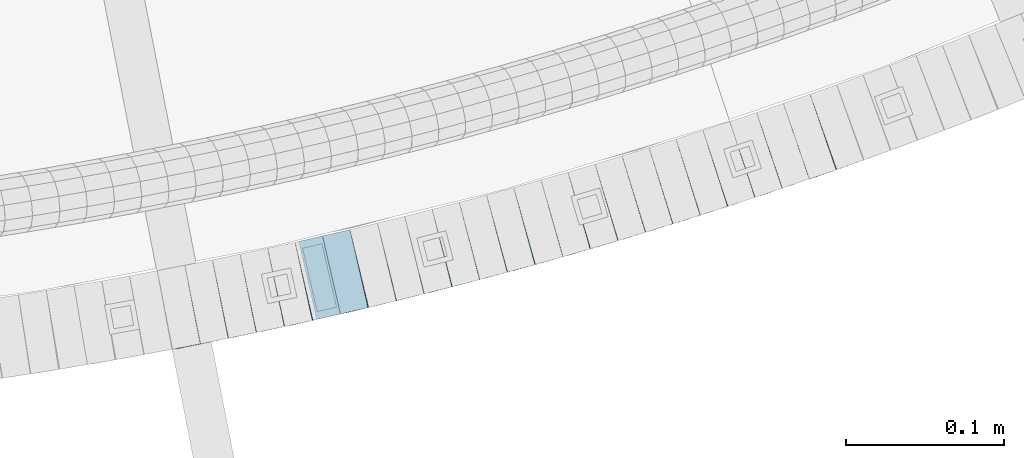
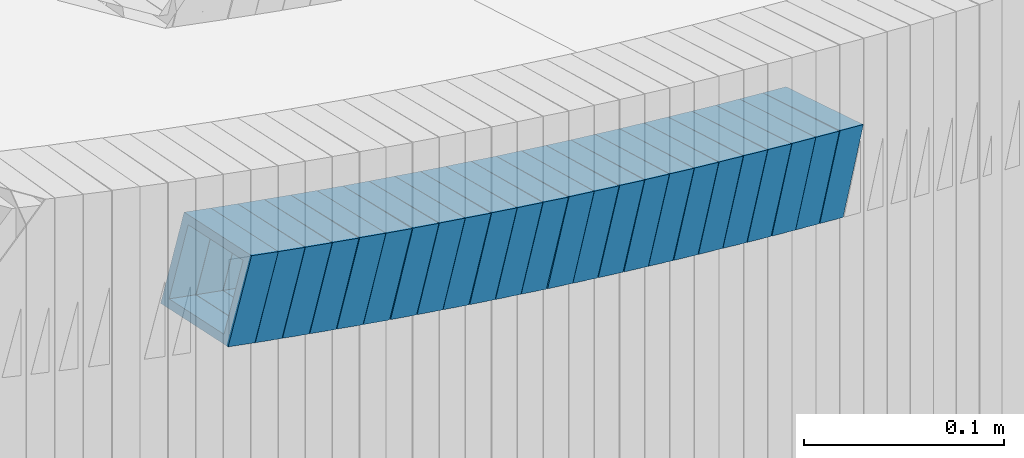
# One storey, part 682 of 975: 24 beams.
"""IFC2X3 building model written with IfcOpenShell, lengths in millimetres."""

from ifc_helpers import new_model, si_unit, frame, origin_with_axes, place, context, subcontext, project, spatial, faceted_brep, material, type_object, element, save


model = new_model("IFC2X3")

# Units and contexts
model_context = context("Model", 3, precision=1e-05, world=origin_with_axes())
body_context = subcontext(model_context, "Body", "Model", "MODEL_VIEW")
ifc_project = project(units=[si_unit("LENGTHUNIT", "METRE", prefix="MILLI"), si_unit("AREAUNIT", "SQUARE_METRE"), si_unit("VOLUMEUNIT", "CUBIC_METRE"), si_unit("MASSUNIT", "GRAM", prefix="KILO"), si_unit("TIMEUNIT", "SECOND"), si_unit("PLANEANGLEUNIT", "RADIAN"), si_unit("SOLIDANGLEUNIT", "STERADIAN"), si_unit("THERMODYNAMICTEMPERATUREUNIT", "DEGREE_CELSIUS"), si_unit("LUMINOUSINTENSITYUNIT", "LUMEN")], contexts=[model_context])

# Site, building, storey
site_placement = place(None, origin_with_axes())
site = spatial("IfcSite", under=ifc_project, at=site_placement, CompositionType="ELEMENT")
building_placement = place(site_placement, origin_with_axes())
building = spatial("IfcBuilding", under=site, at=building_placement, Name="Undefined", CompositionType="ELEMENT")
storey_placement = place(building_placement, origin_with_axes())
storey = spatial("IfcBuildingStorey", under=building, at=storey_placement, Name="Undefined", CompositionType="ELEMENT", Elevation=0.0)

# Beams
ifc_material = material()
beam_type = type_object("IfcBeamType", Name="HSS2X2X.188_TUBES", PredefinedType="NOTDEFINED")
beam_1_placement = place(storey_placement, frame((35282.5013418512, 585.514626684932, 3113.14111426642), z_axis=(-0.201494991724154, 0.979489544768132, -7.25458448869176e-11), x_axis=(0.931628976123351, 0.191649389025373, -0.308768461040888)))
element("IfcBeam", 1, at=beam_1_placement, inside=storey, type_object=beam_type, material=ifc_material, Name="WALL", ObjectType="HSS2X2X.188_TUBES", context=body_context, shape_type="Brep", body=[
    faceted_brep([(0.0, 20.6374999999753, -20.6375000000298), (0.0, -20.6375000000153, -20.6375000000153), (18.7771137292038, -20.637500000008, -20.6374999999862), (18.777113729182, 20.6375000000062, -20.6375000000189), (0.0, -20.6374999999825, 20.6375000000335), (18.7771137291729, -20.6374999999916, 20.6374999999753), (0.0, 20.6375000000116, 20.6375000000189), (18.7771137291529, 20.6375000000207, 20.6374999999389), (0.0, 25.3999999999724, -25.4000000000342), (0.0, 25.400000000016, 25.4000000000196), (18.7771137291475, 25.4000000000251, 25.3999999999287), (18.7771137291857, 25.4000000000051, -25.4000000000196), (0.0, -25.399999999976, 25.4000000000378), (18.7771137291711, -25.3999999999905, 25.3999999999724), (0.0, -25.400000000016, -25.4000000000196), (18.7771137292129, -25.4000000000124, -25.3999999999724)], [[[0, 1, 2, 3]], [[1, 4, 5, 2]], [[4, 6, 7, 5]], [[6, 0, 3, 7]], [[8, 9, 10, 11]], [[9, 12, 13, 10]], [[12, 14, 15, 13]], [[14, 8, 11, 15]], [[13, 15, 11, 10], [5, 7, 3, 2]], [[14, 12, 9, 8], [6, 4, 1, 0]]]),
])
beam_2_placement = place(storey_placement, frame((35300.1214551458, 589.139335705527, 3107.30164874972), z_axis=(-0.201494991724154, 0.979489544768132, -7.25458448869176e-11), x_axis=(0.933150868224818, 0.191962464046246, -0.303940569073235)))
element("IfcBeam", 2, at=beam_2_placement, inside=storey, type_object=beam_type, material=ifc_material, Name="WALL", ObjectType="HSS2X2X.188_TUBES", context=body_context, shape_type="Brep", body=[
    faceted_brep([(0.0, 20.6374999999753, -20.6375000000298), (0.0, -20.6375000000153, -20.6375000000153), (18.7547327359644, -20.6374999999844, -20.6375000000553), (18.7547327359898, 20.6375000000171, -20.6375000000335), (0.0, -20.6374999999825, 20.6375000000335), (18.7547327360044, -20.6374999999953, 20.6374999999898), (0.0, 20.6375000000116, 20.6375000000189), (18.7547327360262, 20.6375000000062, 20.6375000000116), (0.0, 25.3999999999724, -25.4000000000342), (0.0, 25.400000000016, 25.4000000000196), (18.7547327360371, 25.4000000000033, 25.4000000000124), (18.7547327359898, 25.4000000000178, -25.4000000000342), (0.0, -25.399999999976, 25.4000000000378), (18.7547327360044, -25.399999999996, 25.3999999999869), (0.0, -25.400000000016, -25.4000000000196), (18.7547327359498, -25.3999999999814, -25.4000000000597)], [[[0, 1, 2, 3]], [[1, 4, 5, 2]], [[4, 6, 7, 5]], [[6, 0, 3, 7]], [[8, 9, 10, 11]], [[9, 12, 13, 10]], [[12, 14, 15, 13]], [[14, 8, 11, 15]], [[13, 15, 11, 10], [5, 7, 3, 2]], [[14, 12, 9, 8], [6, 4, 1, 0]]]),
])
beam_3_placement = place(storey_placement, frame((35317.7740748872, 592.72800463653, 3101.59909806896), z_axis=(-0.206855682063266, 0.978371466672113, 4.13369889429304e-11), x_axis=(0.932183934090213, 0.197090318019077, -0.303625624029385)))
element("IfcBeam", 3, at=beam_3_placement, inside=storey, type_object=beam_type, material=ifc_material, Name="WALL", ObjectType="HSS2X2X.188_TUBES", context=body_context, shape_type="Brep", body=[
    faceted_brep([(0.0, 20.6374999999753, -20.6375000000298), (0.0, -20.6375000000153, -20.6375000000153), (18.767258723612, -20.6375000000025, -20.6374999999862), (18.7672587236229, 20.6374999999953, -20.637499999968), (0.0, -20.6374999999825, 20.6375000000335), (18.767258723612, -20.6375000000135, 20.6375000000153), (0.0, 20.6375000000116, 20.6375000000189), (18.7672587236266, 20.6374999999844, 20.6375000000371), (0.0, 25.3999999999724, -25.4000000000342), (0.0, 25.400000000016, 25.4000000000196), (18.7672587236302, 25.3999999999814, 25.4000000000342), (18.7672587236229, 25.399999999996, -25.3999999999687), (0.0, -25.399999999976, 25.4000000000378), (18.7672587236157, -25.4000000000142, 25.400000000016), (0.0, -25.400000000016, -25.4000000000196), (18.767258723612, -25.4000000000015, -25.3999999999905)], [[[0, 1, 2, 3]], [[1, 4, 5, 2]], [[4, 6, 7, 5]], [[6, 0, 3, 7]], [[8, 9, 10, 11]], [[9, 12, 13, 10]], [[12, 14, 15, 13]], [[14, 8, 11, 15]], [[13, 15, 11, 10], [5, 7, 3, 2]], [[14, 12, 9, 8], [6, 4, 1, 0]]]),
])
beam_4_placement = place(storey_placement, frame((35335.4206572032, 596.406909101109, 3095.9087282953), z_axis=(-0.213361967308316, 0.976973219134652, 8.72073542268481e-11), x_axis=(0.93048128345778, 0.203208556099976, -0.304812834149952)))
element("IfcBeam", 4, at=beam_4_placement, inside=storey, type_object=beam_type, material=ifc_material, Name="WALL", ObjectType="HSS2X2X.188_TUBES", context=body_context, shape_type="Brep", body=[
    faceted_brep([(0.0, 20.6374999999753, -20.6375000000298), (0.0, -20.6375000000153, -20.6375000000153), (18.6959888745805, -20.6374999999771, -20.6375000000407), (18.6959888746751, 20.637499999988, -20.6374999999716), (0.0, -20.6374999999825, 20.6375000000335), (18.6959888746969, -20.6375000000135, 20.6375000000371), (0.0, 20.6375000000116, 20.6375000000189), (18.6959888747988, 20.6374999999498, 20.6375000001062), (0.0, 25.3999999999724, -25.4000000000342), (0.0, 25.400000000016, 25.4000000000196), (18.695988874817, 25.3999999999414, 25.4000000001215), (18.6959888746678, 25.3999999999887, -25.399999999976), (0.0, -25.399999999976, 25.4000000000378), (18.6959888747042, -25.4000000000124, 25.4000000000378), (0.0, -25.400000000016, -25.4000000000196), (18.695988874555, -25.3999999999687, -25.4000000000597)], [[[0, 1, 2, 3]], [[1, 4, 5, 2]], [[4, 6, 7, 5]], [[6, 0, 3, 7]], [[8, 9, 10, 11]], [[9, 12, 13, 10]], [[12, 14, 15, 13]], [[14, 8, 11, 15]], [[13, 15, 11, 10], [5, 7, 3, 2]], [[14, 12, 9, 8], [6, 4, 1, 0]]]),
])
beam_5_placement = place(storey_placement, frame((35353.0076464014, 600.161392125464, 3090.24273988116), z_axis=(-0.22404129930948, 0.974579651031007, 9.57256816036534e-11), x_axis=(0.926896619822823, 0.213079682959272, -0.308965539940949)))
element("IfcBeam", 5, at=beam_5_placement, inside=storey, type_object=beam_type, material=ifc_material, Name="WALL", ObjectType="HSS2X2X.188_TUBES", context=body_context, shape_type="Brep", body=[
    faceted_brep([(0.0, 20.6374999999753, -20.6375000000298), (0.0, -20.6375000000153, -20.6375000000153), (18.767258723612, -20.6375000000025, -20.6374999999862), (18.7672587236229, 20.6374999999953, -20.637499999968), (0.0, -20.6374999999825, 20.6375000000335), (18.767258723612, -20.6375000000135, 20.6375000000153), (0.0, 20.6375000000116, 20.6375000000189), (18.7672587236266, 20.6374999999844, 20.6375000000371), (0.0, 25.3999999999724, -25.4000000000342), (0.0, 25.400000000016, 25.4000000000196), (18.7672587236302, 25.3999999999814, 25.4000000000342), (18.7672587236229, 25.399999999996, -25.3999999999687), (0.0, -25.399999999976, 25.4000000000378), (18.7672587236157, -25.4000000000142, 25.400000000016), (0.0, -25.400000000016, -25.4000000000196), (18.767258723612, -25.4000000000015, -25.3999999999905)], [[[0, 1, 2, 3]], [[1, 4, 5, 2]], [[4, 6, 7, 5]], [[6, 0, 3, 7]], [[8, 9, 10, 11]], [[9, 12, 13, 10]], [[12, 14, 15, 13]], [[14, 8, 11, 15]], [[13, 15, 11, 10], [5, 7, 3, 2]], [[14, 12, 9, 8], [6, 4, 1, 0]]]),
])
beam_6_placement = place(storey_placement, frame((35370.5272181666, 604.18887988757, 3084.40322650391), z_axis=(-0.22404129930948, 0.974579651031007, 9.57256816036534e-11), x_axis=(0.928412719816282, 0.213428210957765, -0.304135200939816)))
element("IfcBeam", 6, at=beam_6_placement, inside=storey, type_object=beam_type, material=ifc_material, Name="WALL", ObjectType="HSS2X2X.188_TUBES", context=body_context, shape_type="Brep", body=[
    faceted_brep([(0.0, 20.6374999999753, -20.6375000000298), (0.0, -20.6375000000153, -20.6375000000153), (18.7416648140024, -20.6375000000153, -20.6374999999825), (18.7416648139188, 20.6375000000189, -20.6375000000298), (0.0, -20.6374999999825, 20.6375000000335), (18.7416648140097, -20.6375000000189, 20.6375000000226), (0.0, 20.6375000000116, 20.6375000000189), (18.741664813926, 20.6375000000153, 20.6374999999753), (0.0, 25.3999999999724, -25.4000000000342), (0.0, 25.400000000016, 25.4000000000196), (18.7416648139224, 25.4000000000196, 25.3999999999687), (18.7416648139042, 25.4000000000233, -25.4000000000378), (0.0, -25.399999999976, 25.4000000000378), (18.7416648140133, -25.4000000000215, 25.4000000000269), (0.0, -25.400000000016, -25.4000000000196), (18.7416648140133, -25.4000000000196, -25.399999999976)], [[[0, 1, 2, 3]], [[1, 4, 5, 2]], [[4, 6, 7, 5]], [[6, 0, 3, 7]], [[8, 9, 10, 11]], [[9, 12, 13, 10]], [[12, 14, 15, 13]], [[14, 8, 11, 15]], [[13, 15, 11, 10], [5, 7, 3, 2]], [[14, 12, 9, 8], [6, 4, 1, 0]]]),
])
beam_7_placement = place(storey_placement, frame((35388.233201155, 608.174652286864, 3078.69749634809), z_axis=(-0.23464053321012, 0.972082208547647, 9.88425199466292e-11), x_axis=(0.926252882322639, 0.223578282077912, -0.303427668105751)))
element("IfcBeam", 7, at=beam_7_placement, inside=storey, type_object=beam_type, material=ifc_material, Name="WALL", ObjectType="HSS2X2X.188_TUBES", context=body_context, shape_type="Brep", body=[
    faceted_brep([(0.0, 20.6374999999753, -20.6375000000298), (0.0, -20.6375000000153, -20.6375000000153), (18.7853666454903, -20.6375000000535, -20.6375000000326), (18.785366645363, 20.6374999999862, -20.6375000000044), (0.0, -20.6374999999825, 20.6375000000335), (18.785366645352, -20.6375000000007, 20.6374999999989), (0.0, 20.6375000000116, 20.6375000000189), (18.7853666453102, 20.6375000000025, 20.6374999999753), (0.0, 25.3999999999724, -25.4000000000342), (0.0, 25.400000000016, 25.4000000000196), (18.7853666452065, 25.4000000000451, 25.4000000000351), (18.7853666453739, 25.3999999999833, -25.400000000006), (0.0, -25.399999999976, 25.4000000000378), (18.7853666497213, -25.399999993424, 25.3999999995158), (0.0, -25.400000000016, -25.4000000000196), (18.7853666455194, -25.4000000000633, -25.4000000000406)], [[[0, 1, 2, 3]], [[1, 4, 5, 2]], [[4, 6, 7, 5]], [[6, 0, 3, 7]], [[8, 9, 10, 11]], [[9, 12, 13, 10]], [[12, 14, 15, 13]], [[14, 8, 11, 15]], [[13, 15, 11, 10], [5, 7, 3, 2]], [[14, 12, 9, 8], [6, 4, 1, 0]]]),
])
beam_8_placement = place(storey_placement, frame((35405.784697052, 612.35794877395, 3073.00667688811), z_axis=(-0.241215480087368, 0.970471582358917, -5.72072167415172e-13), x_axis=(0.924367424052867, 0.229756065013139, -0.304560365017422)))
element("IfcBeam", 8, at=beam_8_placement, inside=storey, type_object=beam_type, material=ifc_material, Name="WALL", ObjectType="HSS2X2X.188_TUBES", context=body_context, shape_type="Brep", body=[
    faceted_brep([(0.0, 20.6374999999753, -20.6375000000298), (0.0, -20.6375000000153, -20.6375000000153), (18.724849799155, -20.6375000000171, -20.6374999999425), (18.7248497991204, 20.6374999999989, -20.6375000000007), (0.0, -20.6374999999825, 20.6375000000335), (18.7248497991168, -20.6374999999953, 20.6375000000007), (0.0, 20.6375000000116, 20.6375000000189), (18.724849799084, 20.6375000000226, 20.6374999999498), (0.0, 25.3999999999724, -25.4000000000342), (0.0, 25.400000000016, 25.4000000000196), (18.7248497990731, 25.4000000000269, 25.399999999936), (18.7248497991204, 25.3999999999978, -25.3999999999978), (0.0, -25.399999999976, 25.4000000000378), (18.7248497991186, -25.3999999999942, 25.4000000000051), (0.0, -25.400000000016, -25.4000000000196), (18.7248497991604, -25.4000000000233, -25.3999999999323)], [[[0, 1, 2, 3]], [[1, 4, 5, 2]], [[4, 6, 7, 5]], [[6, 0, 3, 7]], [[8, 9, 10, 11]], [[9, 12, 13, 10]], [[12, 14, 15, 13]], [[14, 8, 11, 15]], [[13, 15, 11, 10], [5, 7, 3, 2]], [[14, 12, 9, 8], [6, 4, 1, 0]]]),
])
beam_9_placement = place(storey_placement, frame((35423.1199855391, 616.634234163909, 3067.33070383533), z_axis=(-0.245156736446225, 0.969483457607729, 1.70881321537309e-10), x_axis=(0.922509166252552, 0.233278180063863, -0.307503055084193)))
element("IfcBeam", 9, at=beam_9_placement, inside=storey, type_object=beam_type, material=ifc_material, Name="WALL", ObjectType="HSS2X2X.188_TUBES", context=body_context, shape_type="Brep", body=[
    faceted_brep([(0.0, 20.6374999999753, -20.6375000000298), (0.0, -20.6375000000153, -20.6375000000153), (18.8565638439322, -20.6375000000116, -20.6374999999643), (18.8565638439395, 20.637499999988, -20.6374999999534), (0.0, -20.6374999999825, 20.6375000000335), (18.856563843914, -20.6374999999953, 20.6375000000116), (0.0, 20.6375000000116, 20.6375000000189), (18.8565638439177, 20.6375000000007, 20.6375000000226), (0.0, 25.3999999999724, -25.4000000000342), (0.0, 25.400000000016, 25.4000000000196), (18.8565638439177, 25.4000000000033, 25.4000000000233), (18.8565638439468, 25.3999999999851, -25.3999999999505), (0.0, -25.399999999976, 25.4000000000378), (18.8565638439104, -25.399999999996, 25.4000000000087), (0.0, -25.400000000016, -25.4000000000196), (18.8565638439395, -25.4000000000124, -25.3999999999614)], [[[0, 1, 2, 3]], [[1, 4, 5, 2]], [[4, 6, 7, 5]], [[6, 0, 3, 7]], [[8, 9, 10, 11]], [[9, 12, 13, 10]], [[12, 14, 15, 13]], [[14, 8, 11, 15]], [[13, 15, 11, 10], [5, 7, 3, 2]], [[14, 12, 9, 8], [6, 4, 1, 0]]]),
])
beam_10_placement = place(storey_placement, frame((35440.7921342811, 621.03826096374, 3061.5126737873), z_axis=(-0.253108736064504, 0.967437836621987, 5.06815922562965e-11), x_axis=(0.921249391693007, 0.241024549919681, -0.305297763898265)))
element("IfcBeam", 10, at=beam_10_placement, inside=storey, type_object=beam_type, material=ifc_material, Name="WALL", ObjectType="HSS2X2X.188_TUBES", context=body_context, shape_type="Brep", body=[
    faceted_brep([(0.0, 20.6374999999753, -20.6375000000298), (0.0, -20.6375000000153, -20.6375000000153), (18.6689581926366, -20.6374999999953, -20.6374999999916), (18.6689581926476, 20.6375000000062, -20.6374999999935), (0.0, -20.6374999999825, 20.6375000000335), (18.6689581927276, -20.6375000000116, 20.6374999999862), (0.0, 20.6375000000116, 20.6375000000189), (18.6689581927312, 20.6374999999862, 20.6374999999844), (0.0, 25.3999999999724, -25.4000000000342), (0.0, 25.400000000016, 25.4000000000196), (18.6689581927458, 25.3999999999833, 25.3999999999814), (18.6689581926366, 25.4000000000087, -25.3999999999905), (0.0, -25.399999999976, 25.4000000000378), (18.6689581927385, -25.4000000000142, 25.3999999999851), (0.0, -25.400000000016, -25.4000000000196), (18.6689581926257, -25.3999999999887, -25.3999999999869)], [[[0, 1, 2, 3]], [[1, 4, 5, 2]], [[4, 6, 7, 5]], [[6, 0, 3, 7]], [[8, 9, 10, 11]], [[9, 12, 13, 10]], [[12, 14, 15, 13]], [[14, 8, 11, 15]], [[13, 15, 11, 10], [5, 7, 3, 2]], [[14, 12, 9, 8], [6, 4, 1, 0]]]),
])
beam_11_placement = place(storey_placement, frame((35458.1444641554, 625.546536472119, 3055.79732250594), z_axis=(-0.256967200877691, 0.966420124828268, -2.35854713537265e-11), x_axis=(0.920864354740887, 0.244854105931104, -0.303406174914633)))
element("IfcBeam", 11, at=beam_11_placement, inside=storey, type_object=beam_type, material=ifc_material, Name="WALL", ObjectType="HSS2X2X.188_TUBES", context=body_context, shape_type="Brep", body=[
    faceted_brep([(0.0, 20.6374999999753, -20.6375000000298), (0.0, -20.6375000000153, -20.6375000000153), (18.7853666454903, -20.6375000000535, -20.6375000000326), (18.785366645363, 20.6374999999862, -20.6375000000044), (0.0, -20.6374999999825, 20.6375000000335), (18.785366645352, -20.6375000000007, 20.6374999999989), (0.0, 20.6375000000116, 20.6375000000189), (18.7853666453102, 20.6375000000025, 20.6374999999753), (0.0, 25.3999999999724, -25.4000000000342), (0.0, 25.400000000016, 25.4000000000196), (18.7853666452065, 25.4000000000451, 25.4000000000351), (18.7853666453739, 25.3999999999833, -25.400000000006), (0.0, -25.399999999976, 25.4000000000378), (18.7853666497213, -25.399999993424, 25.3999999995158), (0.0, -25.400000000016, -25.4000000000196), (18.7853666455194, -25.4000000000633, -25.4000000000406)], [[[0, 1, 2, 3]], [[1, 4, 5, 2]], [[4, 6, 7, 5]], [[6, 0, 3, 7]], [[8, 9, 10, 11]], [[9, 12, 13, 10]], [[12, 14, 15, 13]], [[14, 8, 11, 15]], [[13, 15, 11, 10], [5, 7, 3, 2]], [[14, 12, 9, 8], [6, 4, 1, 0]]]),
])
beam_12_placement = place(storey_placement, frame((35475.4813501179, 630.101181715262, 3050.14574944241), z_axis=(-0.263591925707566, 0.964634281322086, -1.19377091323258e-10), x_axis=(0.917323548600462, 0.250663992890824, -0.309330033865263)))
element("IfcBeam", 12, at=beam_12_placement, inside=storey, type_object=beam_type, material=ifc_material, Name="WALL", ObjectType="HSS2X2X.188_TUBES", context=body_context, shape_type="Brep", body=[
    faceted_brep([(0.0, 20.6374999999753, -20.6375000000298), (0.0, -20.6375000000153, -20.6375000000153), (18.7547327359644, -20.6374999999844, -20.6375000000553), (18.7547327359898, 20.6375000000171, -20.6375000000335), (0.0, -20.6374999999825, 20.6375000000335), (18.7547327360044, -20.6374999999953, 20.6374999999898), (0.0, 20.6375000000116, 20.6375000000189), (18.7547327360262, 20.6375000000062, 20.6375000000116), (0.0, 25.3999999999724, -25.4000000000342), (0.0, 25.400000000016, 25.4000000000196), (18.7547327360371, 25.4000000000033, 25.4000000000124), (18.7547327359898, 25.4000000000178, -25.4000000000342), (0.0, -25.399999999976, 25.4000000000378), (18.7547327360044, -25.399999999996, 25.3999999999869), (0.0, -25.400000000016, -25.4000000000196), (18.7547327359498, -25.3999999999814, -25.4000000000597)], [[[0, 1, 2, 3]], [[1, 4, 5, 2]], [[4, 6, 7, 5]], [[6, 0, 3, 7]], [[8, 9, 10, 11]], [[9, 12, 13, 10]], [[12, 14, 15, 13]], [[14, 8, 11, 15]], [[13, 15, 11, 10], [5, 7, 3, 2]], [[14, 12, 9, 8], [6, 4, 1, 0]]]),
])
beam_13_placement = place(storey_placement, frame((35493.1020803437, 634.843566786849, 3044.28749630086), z_axis=(-0.272516766664296, 0.962151033823088, -8.71095835464076e-11), x_axis=(0.91716871924903, 0.259776111070536, -0.302188538082042)))
element("IfcBeam", 13, at=beam_13_placement, inside=storey, type_object=beam_type, material=ifc_material, Name="WALL", ObjectType="HSS2X2X.188_TUBES", context=body_context, shape_type="Brep", body=[
    faceted_brep([(0.0, 20.6374999999753, -20.6375000000298), (0.0, -20.6375000000153, -20.6375000000153), (18.8565638439322, -20.6375000000116, -20.6374999999643), (18.8565638439395, 20.637499999988, -20.6374999999534), (0.0, -20.6374999999825, 20.6375000000335), (18.856563843914, -20.6374999999953, 20.6375000000116), (0.0, 20.6375000000116, 20.6375000000189), (18.8565638439177, 20.6375000000007, 20.6375000000226), (0.0, 25.3999999999724, -25.4000000000342), (0.0, 25.400000000016, 25.4000000000196), (18.8565638439177, 25.4000000000033, 25.4000000000233), (18.8565638439468, 25.3999999999851, -25.3999999999505), (0.0, -25.399999999976, 25.4000000000378), (18.8565638439104, -25.399999999996, 25.4000000000087), (0.0, -25.400000000016, -25.4000000000196), (18.8565638439395, -25.4000000000124, -25.3999999999614)], [[[0, 1, 2, 3]], [[1, 4, 5, 2]], [[4, 6, 7, 5]], [[6, 0, 3, 7]], [[8, 9, 10, 11]], [[9, 12, 13, 10]], [[12, 14, 15, 13]], [[14, 8, 11, 15]], [[13, 15, 11, 10], [5, 7, 3, 2]], [[14, 12, 9, 8], [6, 4, 1, 0]]]),
])
beam_14_placement = place(storey_placement, frame((35510.4109791764, 639.721528076508, 3038.61149811363), z_axis=(-0.275463535456453, 0.961311521117807, 1.30205989989918e-10), x_axis=(0.915460060881419, 0.262324812966019, -0.305153353960482)))
element("IfcBeam", 14, at=beam_14_placement, inside=storey, type_object=beam_type, material=ifc_material, Name="WALL", ObjectType="HSS2X2X.188_TUBES", context=body_context, shape_type="Brep", body=[
    faceted_brep([(0.0, 20.6374999999753, -20.6375000000298), (0.0, -20.6375000000153, -20.6375000000153), (18.677794302308, -20.6374999999989, -20.6374999999862), (18.6777943022862, 20.6375000000098, -20.6375000000153), (0.0, -20.6374999999825, 20.6375000000335), (18.6777943022862, -20.6375000000044, 20.6374999999862), (0.0, 20.6375000000116, 20.6375000000189), (18.6777943022644, 20.6375000000044, 20.6374999999571), (0.0, 25.3999999999724, -25.4000000000342), (0.0, 25.400000000016, 25.4000000000196), (18.6777943022607, 25.4000000000033, 25.3999999999505), (18.6777943022898, 25.4000000000124, -25.400000000016), (0.0, -25.399999999976, 25.4000000000378), (18.6777943022862, -25.4000000000069, 25.3999999999905), (0.0, -25.400000000016, -25.4000000000196), (18.6777943023117, -25.3999999999978, -25.3999999999796)], [[[0, 1, 2, 3]], [[1, 4, 5, 2]], [[4, 6, 7, 5]], [[6, 0, 3, 7]], [[8, 9, 10, 11]], [[9, 12, 13, 10]], [[12, 14, 15, 13]], [[14, 8, 11, 15]], [[13, 15, 11, 10], [5, 7, 3, 2]], [[14, 12, 9, 8], [6, 4, 1, 0]]]),
])
beam_15_placement = place(storey_placement, frame((35527.694723292, 644.600667147075, 3032.9316623909), z_axis=(-0.284278109884981, 0.958741861107682, -4.55479494121391e-11), x_axis=(0.912251849818007, 0.270493280946039, -0.30761980993862)))
element("IfcBeam", 15, at=beam_15_placement, inside=storey, type_object=beam_type, material=ifc_material, Name="WALL", ObjectType="HSS2X2X.188_TUBES", context=body_context, shape_type="Brep", body=[
    faceted_brep([(0.0, 20.6374999999753, -20.6375000000298), (0.0, -20.6375000000153, -20.6375000000153), (18.8480768248774, -20.6374999999716, -20.6375000000735), (18.8480768249356, 20.6375000000153, -20.6375000000226), (0.0, -20.6374999999825, 20.6375000000335), (18.8480768249283, -20.6374999999935, 20.6374999999716), (0.0, 20.6375000000116, 20.6375000000189), (18.8480768249865, 20.6374999999935, 20.6375000000262), (0.0, 25.3999999999724, -25.4000000000342), (0.0, 25.400000000016, 25.4000000000196), (18.848076825001, 25.3999999999887, 25.4000000000378), (18.8480768249392, 25.4000000000142, -25.4000000000233), (0.0, -25.399999999976, 25.4000000000378), (18.8480768249283, -25.399999999996, 25.3999999999833), (0.0, -25.400000000016, -25.4000000000196), (18.8480768248664, -25.3999999999687, -25.4000000000779)], [[[0, 1, 2, 3]], [[1, 4, 5, 2]], [[4, 6, 7, 5]], [[6, 0, 3, 7]], [[8, 9, 10, 11]], [[9, 12, 13, 10]], [[12, 14, 15, 13]], [[14, 8, 11, 15]], [[13, 15, 11, 10], [5, 7, 3, 2]], [[14, 12, 9, 8], [6, 4, 1, 0]]]),
])
beam_16_placement = place(storey_placement, frame((35545.1714671348, 649.727383517728, 3027.10080897252), z_axis=(-0.290938970371623, 0.956741613769935, 1.34735273604747e-10), x_axis=(0.911510751270916, 0.277184556082386, -0.303836917090305)))
element("IfcBeam", 16, at=beam_16_placement, inside=storey, type_object=beam_type, material=ifc_material, Name="WALL", ObjectType="HSS2X2X.188_TUBES", context=body_context, shape_type="Brep", body=[
    faceted_brep([(0.0, 20.6374999999753, -20.6375000000298), (0.0, -20.6375000000153, -20.6375000000153), (18.7555325170906, -20.6374999999916, -20.6374999999971), (18.7555325171452, 20.637499999988, -20.6374999999571), (0.0, -20.6374999999825, 20.6375000000335), (18.7555325170615, -20.6374999999844, 20.6374999999716), (0.0, 20.6375000000116, 20.6375000000189), (18.7555325171015, 20.6374999999953, 20.637500000008), (0.0, 25.3999999999724, -25.4000000000342), (0.0, 25.400000000016, 25.4000000000196), (18.7555325171015, 25.399999999996, 25.4000000000051), (18.7555325171488, 25.3999999999851, -25.3999999999505), (0.0, -25.399999999976, 25.4000000000378), (18.755532517047, -25.3999999999814, 25.3999999999578), (0.0, -25.400000000016, -25.4000000000196), (18.7555325170979, -25.3999999999924, -25.3999999999978)], [[[0, 1, 2, 3]], [[1, 4, 5, 2]], [[4, 6, 7, 5]], [[6, 0, 3, 7]], [[8, 9, 10, 11]], [[9, 12, 13, 10]], [[12, 14, 15, 13]], [[14, 8, 11, 15]], [[13, 15, 11, 10], [5, 7, 3, 2]], [[14, 12, 9, 8], [6, 4, 1, 0]]]),
])
for number, where, z_axis, x_axis, name in (
    (17, (35562.3073464772, 654.894945252949, 3021.43647766827), (-0.296047810349882, 0.955173122521274, 1.54186636791564e-10), (0.908675082134318, 0.281636137041631, -0.308205583045566), "WALL"),
    (18, (35579.6767985577, 660.235929459093, 3015.59344163506), (-0.30113136767222, 0.953582665217787, -1.20199274533661e-10), (0.908777734279158, 0.286982442088154, -0.30292591109306), "WALL"),
):
    element("IfcBeam", number, at=place(storey_placement, frame(where, z_axis=z_axis, x_axis=x_axis)), inside=storey, type_object=beam_type, material=ifc_material, Name=name, ObjectType="HSS2X2X.188_TUBES", context=body_context, shape_type="Brep", body=[
        faceted_brep([(0.0, 20.6374999999753, -20.6375000000298), (0.0, -20.6375000000153, -20.6375000000153), (18.8225928075335, -20.6374999999935, -20.6375000000298), (18.8225928075699, 20.6374999999898, -20.6374999999825), (0.0, -20.6374999999825, 20.6375000000335), (18.8225928075772, -20.637500000008, 20.6375000000226), (0.0, 20.6375000000116, 20.6375000000189), (18.8225928076135, 20.6374999999753, 20.6375000000698), (0.0, 25.3999999999724, -25.4000000000342), (0.0, 25.400000000016, 25.4000000000196), (18.8225928076281, 25.3999999999705, 25.4000000000815), (18.8225928075663, 25.3999999999905, -25.3999999999796), (0.0, -25.399999999976, 25.4000000000378), (18.8225928075808, -25.4000000000087, 25.4000000000233), (0.0, -25.400000000016, -25.4000000000196), (18.8225928075226, -25.3999999999905, -25.4000000000378)], [[[0, 1, 2, 3]], [[1, 4, 5, 2]], [[4, 6, 7, 5]], [[6, 0, 3, 7]], [[8, 9, 10, 11]], [[9, 12, 13, 10]], [[12, 14, 15, 13]], [[14, 8, 11, 15]], [[13, 15, 11, 10], [5, 7, 3, 2]], [[14, 12, 9, 8], [6, 4, 1, 0]]]),
    ])
beam_17_placement = place(storey_placement, frame((35596.9289246202, 665.641575505447, 3009.88968881059), z_axis=(-0.306189380667595, 0.951970620957598, -9.6292296802858e-11), x_axis=(0.907382086053654, 0.291848039017258, -0.302460695017881)))
element("IfcBeam", 19, at=beam_17_placement, inside=storey, type_object=beam_type, material=ifc_material, Name="WALL", ObjectType="HSS2X2X.188_TUBES", context=body_context, shape_type="Brep", body=[
    faceted_brep([(0.0, 20.6374999999753, -20.6375000000298), (0.0, -20.6375000000153, -20.6375000000153), (18.8480768248774, -20.6374999999716, -20.6375000000735), (18.8480768249356, 20.6375000000153, -20.6375000000226), (0.0, -20.6374999999825, 20.6375000000335), (18.8480768249283, -20.6374999999935, 20.6374999999716), (0.0, 20.6375000000116, 20.6375000000189), (18.8480768249865, 20.6374999999935, 20.6375000000262), (0.0, 25.3999999999724, -25.4000000000342), (0.0, 25.400000000016, 25.4000000000196), (18.848076825001, 25.3999999999887, 25.4000000000378), (18.8480768249392, 25.4000000000142, -25.4000000000233), (0.0, -25.399999999976, 25.4000000000378), (18.8480768249283, -25.399999999996, 25.3999999999833), (0.0, -25.400000000016, -25.4000000000196), (18.8480768248664, -25.3999999999687, -25.4000000000779)], [[[0, 1, 2, 3]], [[1, 4, 5, 2]], [[4, 6, 7, 5]], [[6, 0, 3, 7]], [[8, 9, 10, 11]], [[9, 12, 13, 10]], [[12, 14, 15, 13]], [[14, 8, 11, 15]], [[13, 15, 11, 10], [5, 7, 3, 2]], [[14, 12, 9, 8], [6, 4, 1, 0]]]),
])
beam_18_placement = place(storey_placement, frame((35614.0753547043, 671.099351665539, 3004.23697918738), z_axis=(-0.312873574961078, 0.949794781040133, -1.60484887601342e-11), x_axis=(0.903539805876427, 0.297636641959291, -0.308266521957844)))
element("IfcBeam", 20, at=beam_18_placement, inside=storey, type_object=beam_type, material=ifc_material, Name="WALL", ObjectType="HSS2X2X.188_TUBES", context=body_context, shape_type="Brep", body=[
    faceted_brep([(0.0, 20.6374999999753, -20.6375000000298), (0.0, -20.6375000000153, -20.6375000000153), (18.8066477608099, -20.6374999999862, -20.6375000000116), (18.8066477608172, 20.6375000000062, -20.6374999999971), (0.0, -20.6374999999825, 20.6375000000335), (18.8066477608463, -20.6375000000062, 20.6375000000407), (0.0, 20.6375000000116, 20.6375000000189), (18.8066477608536, 20.6374999999844, 20.637500000048), (0.0, 25.3999999999724, -25.4000000000342), (0.0, 25.400000000016, 25.4000000000196), (18.8066477608591, 25.3999999999814, 25.400000000056), (18.8066477608154, 25.4000000000051, -25.4000000000015), (0.0, -25.399999999976, 25.4000000000378), (18.8066477608518, -25.4000000000087, 25.4000000000451), (0.0, -25.400000000016, -25.4000000000196), (18.8066477608081, -25.3999999999851, -25.4000000000196)], [[[0, 1, 2, 3]], [[1, 4, 5, 2]], [[4, 6, 7, 5]], [[6, 0, 3, 7]], [[8, 9, 10, 11]], [[9, 12, 13, 10]], [[12, 14, 15, 13]], [[14, 8, 11, 15]], [[13, 15, 11, 10], [5, 7, 3, 2]], [[14, 12, 9, 8], [6, 4, 1, 0]]]),
])
for number, where, z_axis, x_axis, name in (
    (21, (35631.2279386981, 676.706390053872, 2998.43294279159), (-0.317900434220246, 0.94812410259553, 1.09141637949506e-10), (0.902101158992568, 0.302469211997511, -0.307775688997475), "WALL"),
    (22, (35648.4957292955, 682.453780247715, 2992.58975745706), (-0.322900627123527, 0.9464328740081, -2.64065420196858e-10), (0.90210115899257, 0.307775688997463, -0.302469211997517), "WALL"),
):
    element("IfcBeam", number, at=place(storey_placement, frame(where, z_axis=z_axis, x_axis=x_axis)), inside=storey, type_object=beam_type, material=ifc_material, Name=name, ObjectType="HSS2X2X.188_TUBES", context=body_context, shape_type="Brep", body=[
        faceted_brep([(0.0, 20.6374999999753, -20.6375000000298), (0.0, -20.6375000000153, -20.6375000000153), (18.8433011969464, -20.6374999999898, -20.6375000000226), (18.8433011969719, 20.6375000000007, -20.6374999999862), (0.0, -20.6374999999825, 20.6375000000335), (18.8433011969828, -20.6375000000044, 20.6375000000189), (0.0, 20.6375000000116, 20.6375000000189), (18.8433011970155, 20.6374999999862, 20.6375000000517), (0.0, 25.3999999999724, -25.4000000000342), (0.0, 25.400000000016, 25.4000000000196), (18.8433011970228, 25.3999999999833, 25.4000000000597), (18.8433011969719, 25.4000000000015, -25.3999999999869), (0.0, -25.399999999976, 25.4000000000378), (18.8433011969864, -25.4000000000051, 25.4000000000196), (0.0, -25.400000000016, -25.4000000000196), (18.8433011969391, -25.3999999999869, -25.4000000000269)], [[[0, 1, 2, 3]], [[1, 4, 5, 2]], [[4, 6, 7, 5]], [[6, 0, 3, 7]], [[8, 9, 10, 11]], [[9, 12, 13, 10]], [[12, 14, 15, 13]], [[14, 8, 11, 15]], [[13, 15, 11, 10], [5, 7, 3, 2]], [[14, 12, 9, 8], [6, 4, 1, 0]]]),
    ])
beam_19_placement = place(storey_placement, frame((35665.5087212364, 688.243516147842, 2986.90150870524), z_axis=(-0.324610482431657, 0.945847786219055, -1.94175299839116e-10), x_axis=(0.90110588298714, 0.309255272995583, -0.303923285995651)))
element("IfcBeam", 23, at=beam_19_placement, inside=storey, type_object=beam_type, material=ifc_material, Name="WALL", ObjectType="HSS2X2X.188_TUBES", context=body_context, shape_type="Brep", body=[
    faceted_brep([(0.0, 20.6374999999753, -20.6375000000298), (0.0, -20.6375000000153, -20.6375000000153), (18.7547327359644, -20.6374999999844, -20.6375000000553), (18.7547327359898, 20.6375000000171, -20.6375000000335), (0.0, -20.6374999999825, 20.6375000000335), (18.7547327360044, -20.6374999999953, 20.6374999999898), (0.0, 20.6375000000116, 20.6375000000189), (18.7547327360262, 20.6375000000062, 20.6375000000116), (0.0, 25.3999999999724, -25.4000000000342), (0.0, 25.400000000016, 25.4000000000196), (18.7547327360371, 25.4000000000033, 25.4000000000124), (18.7547327359898, 25.4000000000178, -25.4000000000342), (0.0, -25.399999999976, 25.4000000000378), (18.7547327360044, -25.399999999996, 25.3999999999869), (0.0, -25.400000000016, -25.4000000000196), (18.7547327359498, -25.3999999999814, -25.4000000000597)], [[[0, 1, 2, 3]], [[1, 4, 5, 2]], [[4, 6, 7, 5]], [[6, 0, 3, 7]], [[8, 9, 10, 11]], [[9, 12, 13, 10]], [[12, 14, 15, 13]], [[14, 8, 11, 15]], [[13, 15, 11, 10], [5, 7, 3, 2]], [[14, 12, 9, 8], [6, 4, 1, 0]]]),
])
beam_20_placement = place(storey_placement, frame((35682.5975544425, 694.022648304653, 2981.23251569548), z_axis=(-0.33456960067727, 0.942371042797184, -7.6417109085014e-11), x_axis=(0.896643204474333, 0.318334865168401, -0.30772370316278)))
element("IfcBeam", 24, at=beam_20_placement, inside=storey, type_object=beam_type, material=ifc_material, Name="WALL", ObjectType="HSS2X2X.188_TUBES", context=body_context, shape_type="Brep", body=[
    faceted_brep([(0.0, 20.6374999999753, -20.6375000000298), (0.0, -20.6375000000153, -20.6375000000153), (18.8480768248774, -20.6374999999716, -20.6375000000735), (18.8480768249356, 20.6375000000153, -20.6375000000226), (0.0, -20.6374999999825, 20.6375000000335), (18.8480768249283, -20.6374999999935, 20.6374999999716), (0.0, 20.6375000000116, 20.6375000000189), (18.8480768249865, 20.6374999999935, 20.6375000000262), (0.0, 25.3999999999724, -25.4000000000342), (0.0, 25.400000000016, 25.4000000000196), (18.848076825001, 25.3999999999887, 25.4000000000378), (18.8480768249392, 25.4000000000142, -25.4000000000233), (0.0, -25.399999999976, 25.4000000000378), (18.8480768249283, -25.399999999996, 25.3999999999833), (0.0, -25.400000000016, -25.4000000000196), (18.8480768248664, -25.3999999999687, -25.4000000000779)], [[[0, 1, 2, 3]], [[1, 4, 5, 2]], [[4, 6, 7, 5]], [[6, 0, 3, 7]], [[8, 9, 10, 11]], [[9, 12, 13, 10]], [[12, 14, 15, 13]], [[14, 8, 11, 15]], [[13, 15, 11, 10], [5, 7, 3, 2]], [[14, 12, 9, 8], [6, 4, 1, 0]]]),
])

save(model, "model.ifc")
